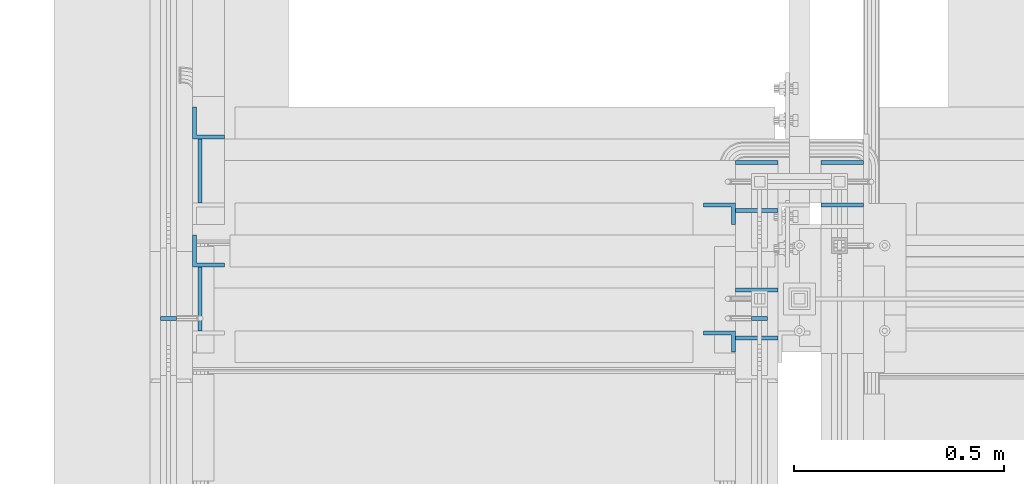
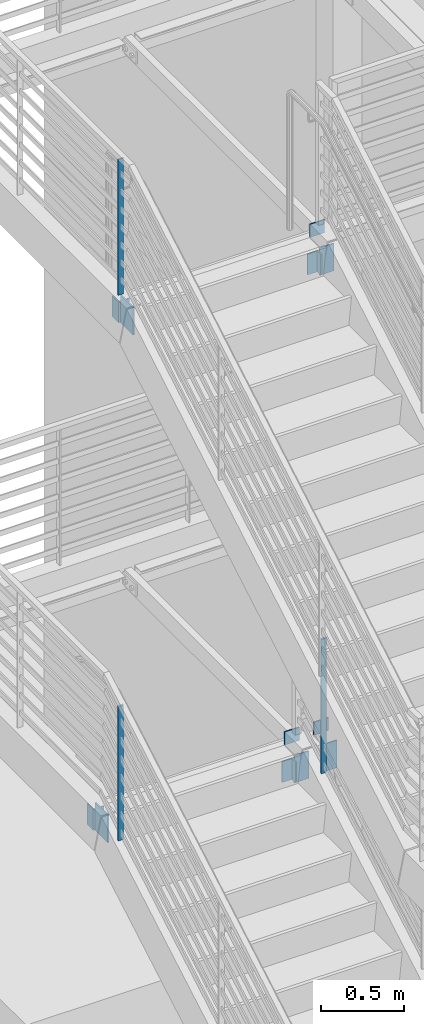
# One storey, part 483 of 1179: 15 columns, 12 elements without a shape of their own.
"""IFC2X3 building model written with IfcOpenShell, lengths in millimetres."""

from ifc_helpers import new_model, si_unit, frame, origin_with_axes, place, context, subcontext, project, spatial, faceted_brep, material, type_object, element, aggregate, save


model = new_model("IFC2X3")

# Units and contexts
model_context = context("Model", 3, precision=1e-05, world=origin_with_axes())
body_context = subcontext(model_context, "Body", "Model", "MODEL_VIEW")
ifc_project = project(units=[si_unit("LENGTHUNIT", "METRE", prefix="MILLI"), si_unit("AREAUNIT", "SQUARE_METRE"), si_unit("VOLUMEUNIT", "CUBIC_METRE"), si_unit("MASSUNIT", "GRAM", prefix="KILO"), si_unit("TIMEUNIT", "SECOND"), si_unit("PLANEANGLEUNIT", "RADIAN"), si_unit("SOLIDANGLEUNIT", "STERADIAN"), si_unit("THERMODYNAMICTEMPERATUREUNIT", "DEGREE_CELSIUS"), si_unit("LUMINOUSINTENSITYUNIT", "LUMEN")], contexts=[model_context])

# Site, building, storey
site_placement = place(None, origin_with_axes())
site = spatial("IfcSite", under=ifc_project, at=site_placement, CompositionType="ELEMENT")
building_placement = place(site_placement, origin_with_axes())
building = spatial("IfcBuilding", under=site, at=building_placement, Name="Undefined", CompositionType="ELEMENT")
storey_placement = place(building_placement, origin_with_axes())
storey = spatial("IfcBuildingStorey", under=building, at=storey_placement, Name="Undefined", CompositionType="ELEMENT", Elevation=0.0)

# Assembly, column
assembly_1_placement = place(storey_placement, origin_with_axes())
assembly_1 = element("IfcElementAssembly", 1, at=assembly_1_placement, inside=storey, Name="GUARDRAIL", AssemblyPlace="NOTDEFINED", PredefinedType="RIGID_FRAME")
ifc_material = material(Name="STEEL/A36")
column_type_1 = type_object("IfcColumnType", PredefinedType="NOTDEFINED")
column_1_placement = place(assembly_1_placement, frame((-1847.85000076555, 35068.9333333333, 4193.65666391107), z_axis=(-1.0, 0.0, 0.0), x_axis=(0.0, 0.0, 1.0)))
column_1 = element("IfcColumn", 2, at=column_1_placement, type_object=column_type_1, material=ifc_material, Name="POST", context=body_context, shape_type="Brep", body=[
    faceted_brep([(2.7574544394347, 4.76250000000073, -19.05), (2.7574544394347, 4.76250000000073, 19.05), (988.755806847296, 4.76249999999709, 19.05), (988.755806847296, 4.76249999999709, -19.05), (-2.75745441634672, -4.76250000000073, 19.05), (983.236057718809, -4.76249999999709, 19.05), (-2.75745441634672, -4.76250000000073, -19.05), (983.236057718809, -4.76249999999709, -19.05)], [[[0, 1, 2, 3]], [[1, 4, 5, 2]], [[4, 6, 7, 5]], [[6, 0, 3, 7]], [[5, 7, 3, 2]], [[6, 4, 1, 0]]]),
])
aggregate(assembly_1, [column_1])

assembly_2_placement = place(storey_placement, origin_with_axes())
assembly_2 = element("IfcElementAssembly", 3, at=assembly_2_placement, inside=storey, Name="GUARDRAIL", AssemblyPlace="NOTDEFINED", PredefinedType="RIGID_FRAME")
column_2_placement = place(assembly_2_placement, frame((-3257.54999923555, 35068.9333333333, 8197.84999979975), z_axis=(-1.0, 0.0, 0.0), x_axis=(0.0, 0.0, 1.0)))
column_2 = element("IfcColumn", 4, at=column_2_placement, type_object=column_type_1, material=ifc_material, Name="POST", context=body_context, shape_type="Brep", body=[
    faceted_brep([(0.0, 4.76250000000073, -19.05), (0.0, 4.76250000000073, 19.0499992370605), (996.89980118088, 4.76249999999709, 19.0500000000002), (996.89980118088, 4.76249999999709, -19.0500000000002), (0.0, -4.76250000000073, 19.0499992370605), (996.89960332758, -4.76249999999709, 19.0500000000002), (0.0, -4.76250000000073, -19.05), (996.89960332758, -4.76249999999709, -19.0500000000002)], [[[0, 1, 2, 3]], [[1, 4, 5, 2]], [[4, 6, 7, 5]], [[6, 0, 3, 7]], [[5, 7, 3, 2]], [[6, 4, 1, 0]]]),
])
aggregate(assembly_2, [column_2])

assembly_3_placement = place(storey_placement, origin_with_axes())
assembly_3 = element("IfcElementAssembly", 5, at=assembly_3_placement, inside=storey, Name="GUARDRAIL", AssemblyPlace="NOTDEFINED", PredefinedType="RIGID_FRAME")
column_3_placement = place(assembly_3_placement, frame((-3257.54999923555, 35068.9333333333, 4193.65666391107), z_axis=(-1.0, 0.0, 0.0), x_axis=(0.0, 0.0, 1.0)))
column_3 = element("IfcColumn", 6, at=column_3_placement, type_object=column_type_1, material=ifc_material, Name="POST", context=body_context, shape_type="Brep", body=[
    faceted_brep([(2.7574544394347, 4.76250000000073, -19.05), (2.7574544394347, 4.76250000000073, 19.05), (988.844187198161, 4.76250000000073, 19.0500000000002), (988.844187198161, 4.76250000000073, -19.0500000000002), (-2.75745441634672, -4.76250000000073, 19.05), (983.329278342379, -4.76250000000073, 19.0500000000002), (-2.75745441634672, -4.76250000000073, -19.05), (983.329278342379, -4.76250000000073, -19.0500000000002)], [[[0, 1, 2, 3]], [[1, 4, 5, 2]], [[4, 6, 7, 5]], [[6, 0, 3, 7]], [[5, 7, 3, 2]], [[6, 4, 1, 0]]]),
])
aggregate(assembly_3, [column_3])

assembly_4_placement = place(storey_placement, origin_with_axes())
assembly_4 = element("IfcElementAssembly", 7, at=assembly_4_placement, inside=storey, Name="ANGLE", AssemblyPlace="NOTDEFINED", PredefinedType="RIGID_FRAME")
column_type_2 = type_object("IfcColumnType", Name="L3X2X3/8", PredefinedType="NOTDEFINED")
column_4_placement = place(assembly_4_placement, frame((-1943.1, 35013.899999853, 7915.27499945061), z_axis=(-1.0, 0.0, 0.0), x_axis=(0.0, 0.0, 1.0)))
column_4 = element("IfcColumn", 8, at=column_4_placement, type_object=column_type_2, material=ifc_material, Name="ANGLE", ObjectType="L3X2X3/8", context=body_context, shape_type="Brep", body=[
    faceted_brep([(0.0, 25.4000000000015, -38.0999999999999), (0.0, 25.4000000000015, 38.0999999999999), (152.4, 25.4000000000015, 38.0999999999999), (152.4, 25.4000000000015, -38.0999999999999), (0.0, 15.875, 38.0999999999999), (152.4, 15.875, 38.0999999999999), (0.0, 15.875, -28.575), (152.4, 15.875, -28.575), (0.0, -25.4000000000015, -28.575), (152.4, -25.4000000000015, -28.575), (0.0, -25.4000000000015, -38.0999999999999), (152.4, -25.4000000000015, -38.0999999999999)], [[[0, 1, 2, 3]], [[1, 4, 5, 2]], [[4, 6, 7, 5]], [[6, 8, 9, 7]], [[8, 10, 11, 9]], [[10, 0, 3, 11]], [[5, 7, 9, 11, 3, 2]], [[10, 8, 6, 4, 1, 0]]]),
])
aggregate(assembly_4, [column_4])

assembly_5_placement = place(storey_placement, origin_with_axes())
assembly_5 = element("IfcElementAssembly", 9, at=assembly_5_placement, inside=storey, Name="ANGLE", AssemblyPlace="NOTDEFINED", PredefinedType="RIGID_FRAME")
column_5_placement = place(assembly_5_placement, frame((-1943.1, 35318.7000000027, 4003.67499945083), z_axis=(-1.0, 0.0, 0.0), x_axis=(0.0, 0.0, 1.0)))
column_5 = element("IfcColumn", 10, at=column_5_placement, type_object=column_type_2, material=ifc_material, Name="ANGLE", ObjectType="L3X2X3/8", context=body_context, shape_type="Brep", body=[
    faceted_brep([(0.0, 25.4000000000015, -38.0999999999999), (0.0, 25.4000000000015, 38.0999999999999), (152.4, 25.4000000000015, 38.0999999999999), (152.4, 25.4000000000015, -38.0999999999999), (0.0, 15.875, 38.0999999999999), (152.4, 15.875, 38.0999999999999), (0.0, 15.875, -28.575), (152.4, 15.875, -28.575), (0.0, -25.4000000000015, -28.575), (152.4, -25.4000000000015, -28.575), (0.0, -25.4000000000015, -38.0999999999999), (152.4, -25.4000000000015, -38.0999999999999)], [[[0, 1, 2, 3]], [[1, 4, 5, 2]], [[4, 6, 7, 5]], [[6, 8, 9, 7]], [[8, 10, 11, 9]], [[10, 0, 3, 11]], [[5, 7, 9, 11, 3, 2]], [[10, 8, 6, 4, 1, 0]]]),
])
aggregate(assembly_5, [column_5])

assembly_6_placement = place(storey_placement, origin_with_axes())
assembly_6 = element("IfcElementAssembly", 11, at=assembly_6_placement, inside=storey, Name="STRINGER", AssemblyPlace="NOTDEFINED", PredefinedType="RIGID_FRAME")
column_type_3 = type_object("IfcColumnType", PredefinedType="NOTDEFINED")
column_6_placement = place(assembly_6_placement, frame((-1854.20000000477, 35021.8375, 7893.04999890203), z_axis=(-1.0, 0.0, 0.0), x_axis=(0.0, 0.0, 1.0)))
column_6 = element("IfcColumn", 12, at=column_6_placement, type_object=column_type_3, material=ifc_material, Name="PLATE", context=body_context, shape_type="Brep", body=[
    faceted_brep([(0.0, 4.76249999999982, -50.7999999999993), (0.0, 4.76249999999982, 50.7999999999993), (200.02500109715, 4.76249999999709, 50.8), (200.02500109715, 4.76249999999709, -50.8), (0.0, -4.76249999999982, 50.7999999999993), (200.02500109715, -4.76249999999709, 50.8), (0.0, -4.76249999999982, -50.7999999999993), (200.02500109715, -4.76249999999709, -50.8)], [[[0, 1, 2, 3]], [[1, 4, 5, 2]], [[4, 6, 7, 5]], [[6, 0, 3, 7]], [[5, 7, 3, 2]], [[6, 4, 1, 0]]]),
])

assembly_7_placement = place(storey_placement, origin_with_axes())
assembly_7 = element("IfcElementAssembly", 13, at=assembly_7_placement, inside=storey, Name="STRINGER", AssemblyPlace="NOTDEFINED", PredefinedType="RIGID_FRAME")
column_7_placement = place(assembly_7_placement, frame((-1650.9999999729, 35339.3375000027, 3981.44999890248), z_axis=(-1.0, 0.0, 0.0), x_axis=(0.0, 0.0, 1.0)))
column_7 = element("IfcColumn", 14, at=column_7_placement, type_object=column_type_3, material=ifc_material, Name="PLATE", context=body_context, shape_type="Brep", body=[
    faceted_brep([(0.0, 4.76249999999982, -50.7999999999993), (0.0, 4.76249999999982, 50.7999999999993), (200.02500109715, 4.76249999999709, 50.8), (200.02500109715, 4.76249999999709, -50.8), (0.0, -4.76249999999982, 50.7999999999993), (200.02500109715, -4.76249999999709, 50.8), (0.0, -4.76249999999982, -50.7999999999993), (200.02500109715, -4.76249999999709, -50.8)], [[[0, 1, 2, 3]], [[1, 4, 5, 2]], [[4, 6, 7, 5]], [[6, 0, 3, 7]], [[5, 7, 3, 2]], [[6, 4, 1, 0]]]),
])

assembly_8_placement = place(storey_placement, origin_with_axes())
assembly_8 = element("IfcElementAssembly", 15, at=assembly_8_placement, inside=storey, Name="STRINGER", AssemblyPlace="NOTDEFINED", PredefinedType="RIGID_FRAME")
column_8_placement = place(assembly_8_placement, frame((-1854.20000000477, 35326.6375000027, 3981.44999890225), z_axis=(-1.0, 0.0, 0.0), x_axis=(0.0, 0.0, 1.0)))
column_8 = element("IfcColumn", 16, at=column_8_placement, type_object=column_type_3, material=ifc_material, Name="PLATE", context=body_context, shape_type="Brep", body=[
    faceted_brep([(0.0, 4.76249999999982, -50.7999999999993), (0.0, 4.76249999999982, 50.7999999999993), (200.02500109715, 4.76249999999709, 50.8), (200.02500109715, 4.76249999999709, -50.8), (0.0, -4.76249999999982, 50.7999999999993), (200.02500109715, -4.76249999999709, 50.8), (0.0, -4.76249999999982, -50.7999999999993), (200.02500109715, -4.76249999999709, -50.8)], [[[0, 1, 2, 3]], [[1, 4, 5, 2]], [[4, 6, 7, 5]], [[6, 0, 3, 7]], [[5, 7, 3, 2]], [[6, 4, 1, 0]]]),
])

# Column
column_type_4 = type_object("IfcColumnType", PredefinedType="NOTDEFINED")
column_9_placement = place(assembly_6_placement, frame((-1854.20000000477, 35136.1374999964, 8102.59999999925), z_axis=(-1.0, 0.0, 0.0), x_axis=(0.0, 0.0, 1.0)))
column_9 = element("IfcColumn", 17, at=column_9_placement, type_object=column_type_4, material=ifc_material, Name="PLATE", context=body_context, shape_type="Brep", body=[
    faceted_brep([(0.0, 4.76249999999982, -50.7999999999993), (0.0, 4.76249999999982, 50.7999999999993), (95.2499999997308, 4.76249999999709, 50.8), (95.2499999997308, 4.76249999999709, -50.8), (0.0, -4.76249999999982, 50.7999999999993), (95.2499999997308, -4.76249999999709, 50.8), (0.0, -4.76249999999982, -50.7999999999993), (95.2499999997308, -4.76249999999709, -50.8)], [[[0, 1, 2, 3]], [[1, 4, 5, 2]], [[4, 6, 7, 5]], [[6, 0, 3, 7]], [[5, 7, 3, 2]], [[6, 4, 1, 0]]]),
])

aggregate(assembly_6, [column_6, column_9])

column_10_placement = place(assembly_7_placement, frame((-1650.9999999729, 35440.9374999991, 4190.99999999947), z_axis=(-1.0, 0.0, 0.0), x_axis=(0.0, 0.0, 1.0)))
column_10 = element("IfcColumn", 18, at=column_10_placement, type_object=column_type_4, material=ifc_material, Name="PLATE", context=body_context, shape_type="Brep", body=[
    faceted_brep([(0.0, 4.76249999999982, -50.7999999999993), (0.0, 4.76249999999982, 50.7999999999993), (95.2499999997308, 4.76249999999709, 50.8), (95.2499999997308, 4.76249999999709, -50.8), (0.0, -4.76249999999982, 50.7999999999993), (95.2499999997308, -4.76249999999709, 50.8), (0.0, -4.76249999999982, -50.7999999999993), (95.2499999997308, -4.76249999999709, -50.8)], [[[0, 1, 2, 3]], [[1, 4, 5, 2]], [[4, 6, 7, 5]], [[6, 0, 3, 7]], [[5, 7, 3, 2]], [[6, 4, 1, 0]]]),
])

aggregate(assembly_7, [column_7, column_10])

column_11_placement = place(assembly_8_placement, frame((-1854.20000000477, 35440.9374999991, 4190.99999999947), z_axis=(-1.0, 0.0, 0.0), x_axis=(0.0, 0.0, 1.0)))
column_11 = element("IfcColumn", 19, at=column_11_placement, type_object=column_type_4, material=ifc_material, Name="PLATE", context=body_context, shape_type="Brep", body=[
    faceted_brep([(0.0, 4.76249999999982, -50.7999999999993), (0.0, 4.76249999999982, 50.7999999999993), (95.2499999997308, 4.76249999999709, 50.8), (95.2499999997308, 4.76249999999709, -50.8), (0.0, -4.76249999999982, 50.7999999999993), (95.2499999997308, -4.76249999999709, 50.8), (0.0, -4.76249999999982, -50.7999999999993), (95.2499999997308, -4.76249999999709, -50.8)], [[[0, 1, 2, 3]], [[1, 4, 5, 2]], [[4, 6, 7, 5]], [[6, 0, 3, 7]], [[5, 7, 3, 2]], [[6, 4, 1, 0]]]),
])

aggregate(assembly_8, [column_8, column_11])

# Assembly, column
assembly_9_placement = place(storey_placement, origin_with_axes())
assembly_9 = element("IfcElementAssembly", 20, at=assembly_9_placement, inside=storey, Name="BEAM", AssemblyPlace="NOTDEFINED", PredefinedType="RIGID_FRAME")
column_type_5 = type_object("IfcColumnType", PredefinedType="NOTDEFINED")
column_12_placement = place(assembly_9_placement, frame((-3182.93749999996, 35420.3000000027, 3978.27499999882), z_axis=(0.0, -1.0, 0.0), x_axis=(0.0, 0.0, 1.0)))
column_12 = element("IfcColumn", 21, at=column_12_placement, type_object=column_type_5, material=ifc_material, Name="PLATE", context=body_context, shape_type="Brep", body=[
    faceted_brep([(0.0, 4.76249999999982, -76.1999999999971), (0.0, 4.76249999999982, 76.1999999999971), (203.2, 4.76249999999982, 76.1999999999971), (203.2, 4.76249999999982, -76.1999999999971), (0.0, -4.76249999999982, 76.1999999999971), (203.2, -4.76249999999982, 76.1999999999971), (0.0, -4.76249999999982, -76.1999999999971), (203.2, -4.76249999999982, -76.1999999999971)], [[[0, 1, 2, 3]], [[1, 4, 5, 2]], [[4, 6, 7, 5]], [[6, 0, 3, 7]], [[5, 7, 3, 2]], [[6, 4, 1, 0]]]),
])
aggregate(assembly_9, [column_12])

assembly_10_placement = place(storey_placement, origin_with_axes())
assembly_10 = element("IfcElementAssembly", 22, at=assembly_10_placement, inside=storey, Name="BEAM", AssemblyPlace="NOTDEFINED", PredefinedType="RIGID_FRAME")
column_13_placement = place(assembly_10_placement, frame((-3182.93749999646, 35115.5, 7889.8749999986), z_axis=(0.0, -1.0, 0.0), x_axis=(0.0, 0.0, 1.0)))
column_13 = element("IfcColumn", 23, at=column_13_placement, type_object=column_type_5, material=ifc_material, Name="PLATE", context=body_context, shape_type="Brep", body=[
    faceted_brep([(0.0, 4.76249999999982, -76.1999999999971), (0.0, 4.76249999999982, 76.1999999999971), (203.2, 4.76249999999982, 76.1999999999971), (203.2, 4.76249999999982, -76.1999999999971), (0.0, -4.76249999999982, 76.1999999999971), (203.2, -4.76249999999982, 76.1999999999971), (0.0, -4.76249999999982, -76.1999999999971), (203.2, -4.76249999999982, -76.1999999999971)], [[[0, 1, 2, 3]], [[1, 4, 5, 2]], [[4, 6, 7, 5]], [[6, 0, 3, 7]], [[5, 7, 3, 2]], [[6, 4, 1, 0]]]),
])
aggregate(assembly_10, [column_13])

assembly_11_placement = place(storey_placement, origin_with_axes())
assembly_11 = element("IfcElementAssembly", 24, at=assembly_11_placement, inside=storey, Name="ANGLE", AssemblyPlace="NOTDEFINED", PredefinedType="RIGID_FRAME")
column_type_6 = type_object("IfcColumnType", Name="L3X3X3/8", PredefinedType="NOTDEFINED")
column_14_placement = place(assembly_11_placement, frame((-3162.29999999027, 35229.8, 7893.05), z_axis=(1.0, 0.0, 0.0), x_axis=(0.0, 0.0, 1.0)))
column_14 = element("IfcColumn", 25, at=column_14_placement, type_object=column_type_6, material=ifc_material, Name="ANGLE", ObjectType="L3X3X3/8", context=body_context, shape_type="Brep", body=[
    faceted_brep([(0.0, 38.0999999999985, -38.0999999999999), (0.0, 38.0999999999985, 38.0999999999999), (152.400000000001, 38.0999999999985, 38.0999999999999), (152.400000000001, 38.0999999999985, -38.0999999999999), (0.0, 28.5750000000007, 38.0999999999999), (152.400000000001, 28.5750000000007, 38.0999999999999), (0.0, 28.5750000000007, -28.575), (152.400000000001, 28.5750000000007, -28.575), (0.0, -38.0999999999985, -28.575), (152.400000000001, -38.0999999999985, -28.575), (0.0, -38.0999999999985, -38.0999999999999), (152.400000000001, -38.0999999999985, -38.0999999999999)], [[[0, 1, 2, 3]], [[1, 4, 5, 2]], [[4, 6, 7, 5]], [[6, 8, 9, 7]], [[8, 10, 11, 9]], [[10, 0, 3, 11]], [[5, 7, 9, 11, 3, 2]], [[10, 8, 6, 4, 1, 0]]]),
])
aggregate(assembly_11, [column_14])

assembly_12_placement = place(storey_placement, origin_with_axes())
assembly_12 = element("IfcElementAssembly", 26, at=assembly_12_placement, inside=storey, Name="ANGLE", AssemblyPlace="NOTDEFINED", PredefinedType="RIGID_FRAME")
column_15_placement = place(assembly_12_placement, frame((-3162.29999998944, 35534.6000000019, 3981.45), z_axis=(1.0, 0.0, 0.0), x_axis=(0.0, 0.0, 1.0)))
column_15 = element("IfcColumn", 27, at=column_15_placement, type_object=column_type_6, material=ifc_material, Name="ANGLE", ObjectType="L3X3X3/8", context=body_context, shape_type="Brep", body=[
    faceted_brep([(0.0, 38.0999999999985, -38.0999999999999), (0.0, 38.0999999999985, 38.0999999999999), (152.400000000001, 38.0999999999985, 38.0999999999999), (152.400000000001, 38.0999999999985, -38.0999999999999), (0.0, 28.5750000000007, 38.0999999999999), (152.400000000001, 28.5750000000007, 38.0999999999999), (0.0, 28.5750000000007, -28.575), (152.400000000001, 28.5750000000007, -28.575), (0.0, -38.0999999999985, -28.575), (152.400000000001, -38.0999999999985, -28.575), (0.0, -38.0999999999985, -38.0999999999999), (152.400000000001, -38.0999999999985, -38.0999999999999)], [[[0, 1, 2, 3]], [[1, 4, 5, 2]], [[4, 6, 7, 5]], [[6, 8, 9, 7]], [[8, 10, 11, 9]], [[10, 0, 3, 11]], [[5, 7, 9, 11, 3, 2]], [[10, 8, 6, 4, 1, 0]]]),
])
aggregate(assembly_12, [column_15])

save(model, "model.ifc")
